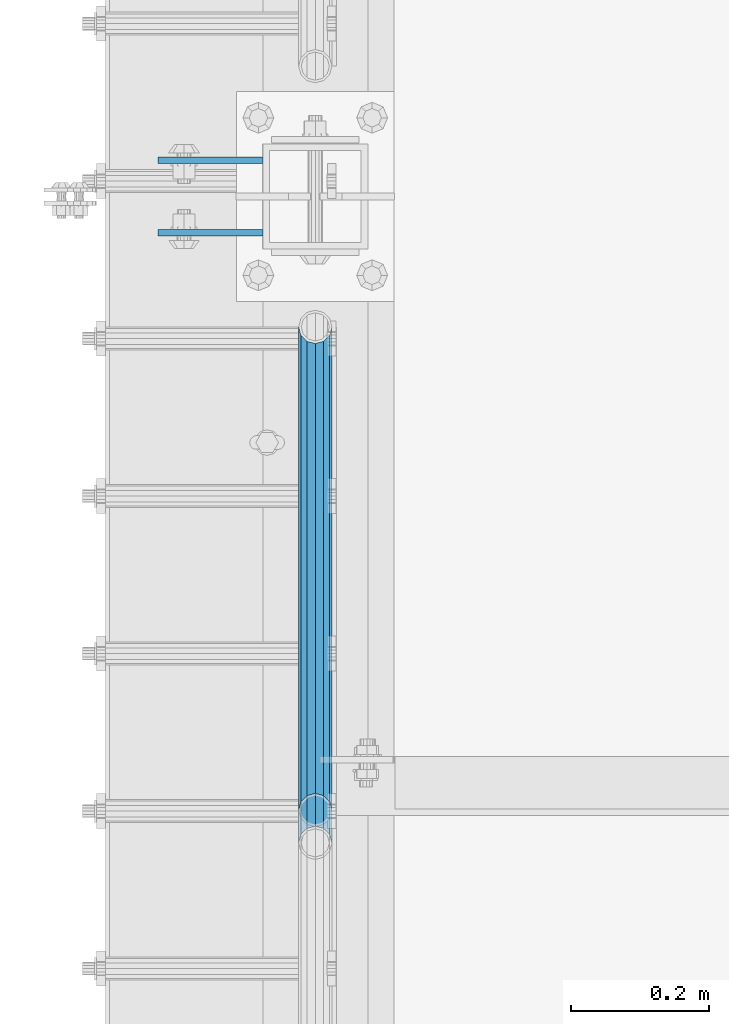
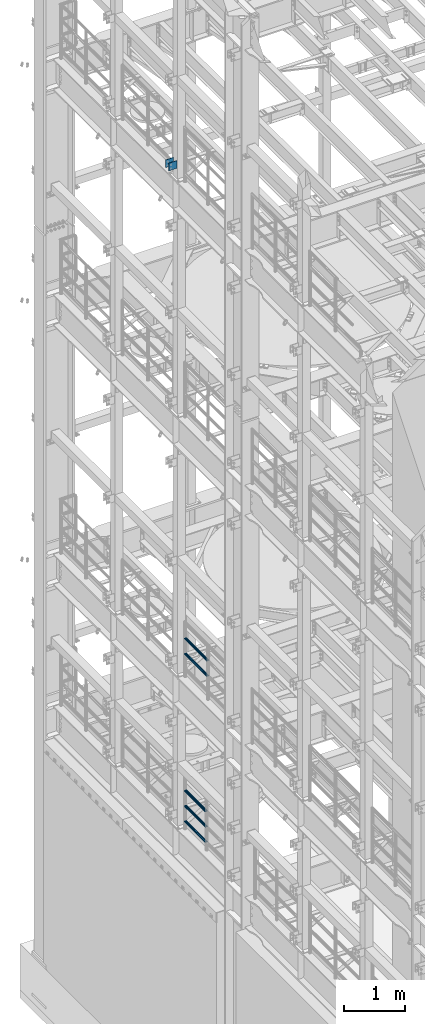
# One storey, part 1296 of 1876: 7 beams, 3 elements without a shape of their own.
"""IFC2X3 building model written with IfcOpenShell, lengths in millimetres."""

from ifc_helpers import new_model, si_unit, frame, origin_with_axes, place, context, subcontext, project, spatial, faceted_brep, material, type_object, element, aggregate, save


model = new_model("IFC2X3")

# Units and contexts
model_context = context("Model", 3, precision=1e-05, world=origin_with_axes())
body_context = subcontext(model_context, "Body", "Model", "MODEL_VIEW")
ifc_project = project(units=[si_unit("LENGTHUNIT", "METRE", prefix="MILLI"), si_unit("AREAUNIT", "SQUARE_METRE"), si_unit("VOLUMEUNIT", "CUBIC_METRE"), si_unit("MASSUNIT", "GRAM", prefix="KILO"), si_unit("TIMEUNIT", "SECOND"), si_unit("PLANEANGLEUNIT", "RADIAN"), si_unit("SOLIDANGLEUNIT", "STERADIAN"), si_unit("THERMODYNAMICTEMPERATUREUNIT", "DEGREE_CELSIUS"), si_unit("LUMINOUSINTENSITYUNIT", "LUMEN")], contexts=[model_context])

# Site, building, storey
site_placement = place(None, origin_with_axes())
site = spatial("IfcSite", under=ifc_project, at=site_placement, CompositionType="ELEMENT")
building_placement = place(site_placement, origin_with_axes())
building = spatial("IfcBuilding", under=site, at=building_placement, Name="Undefined", CompositionType="ELEMENT")
storey_placement = place(building_placement, origin_with_axes())
storey = spatial("IfcBuildingStorey", under=building, at=storey_placement, Name="Undefined", CompositionType="ELEMENT", Elevation=0.0)

# Assembly, beams
assembly_1_placement = place(storey_placement, origin_with_axes())
assembly_1 = element("IfcElementAssembly", 1, at=assembly_1_placement, inside=storey, Name="BEAM", AssemblyPlace="NOTDEFINED", PredefinedType="RIGID_FRAME")
ifc_material_1 = material(Name="STEEL/A36")
beam_type_1 = type_object("IfcBeamType", PredefinedType="NOTDEFINED")
beam_1_placement = place(assembly_1_placement, frame((-76.2000002548894, 9704.3875, 18275.3), z_axis=(0.0, 0.0, -1.0), x_axis=(-1.0, 0.0, 0.0)))
beam_1 = element("IfcBeam", 2, at=beam_1_placement, type_object=beam_type_1, material=ifc_material_1, Name="PLATE", context=body_context, shape_type="Brep", body=[
    faceted_brep([(0.0, 4.76249999999982, -76.1999999999998), (3.63797880709171e-12, 4.76249999999982, 76.1999969482422), (152.399993896484, 4.76250000000073, 76.1999969482422), (152.4, 4.76249999999982, -76.1999999999998), (3.63797880709171e-12, -4.76249999999982, 76.1999969482422), (152.399993896484, -4.76250000000073, 76.1999969482422), (0.0, -4.76249999999982, -76.1999999999998), (152.4, -4.76249999999982, -76.1999999999998)], [[[0, 1, 2, 3]], [[4, 5, 2, 1]], [[4, 6, 7, 5]], [[6, 0, 3, 7]], [[5, 7, 3, 2]], [[6, 4, 1, 0]]]),
])
beam_2_placement = place(assembly_1_placement, frame((-76.2000002548894, 9599.6125, 18275.3), z_axis=(0.0, 0.0, -1.0), x_axis=(-1.0, 0.0, 0.0)))
beam_2 = element("IfcBeam", 3, at=beam_2_placement, type_object=beam_type_1, material=ifc_material_1, Name="PLATE", context=body_context, shape_type="Brep", body=[
    faceted_brep([(0.0, 4.76249999999982, -76.1999999999998), (3.63797880709171e-12, 4.76249999999982, 76.1999969482422), (152.399993896484, 4.76250000000073, 76.1999969482422), (152.4, 4.76249999999982, -76.1999999999998), (3.63797880709171e-12, -4.76249999999982, 76.1999969482422), (152.399993896484, -4.76250000000073, 76.1999969482422), (0.0, -4.76249999999982, -76.1999999999998), (152.4, -4.76249999999982, -76.1999999999998)], [[[0, 1, 2, 3]], [[4, 5, 2, 1]], [[4, 6, 7, 5]], [[6, 0, 3, 7]], [[5, 7, 3, 2]], [[6, 4, 1, 0]]]),
])
aggregate(assembly_1, [beam_1, beam_2])

assembly_2_placement = place(storey_placement, origin_with_axes())
assembly_2 = element("IfcElementAssembly", 4, at=assembly_2_placement, inside=storey, Name="RAIL", AssemblyPlace="NOTDEFINED", PredefinedType="RIGID_FRAME")
ifc_material_2 = material()
beam_type_2 = type_object("IfcBeamType", Name="PIPE1-1/2SCH40", PredefinedType="NOTDEFINED")
beam_3_placement = place(assembly_2_placement, frame((-1.81898940354586e-12, 8713.7875, 8620.125), z_axis=(0.0, 0.0, -1.0), x_axis=(0.0, 1.0, 0.0)))
beam_3 = element("IfcBeam", 5, at=beam_3_placement, type_object=beam_type_2, material=ifc_material_2, Name="RAIL", ObjectType="PIPE1-1/2SCH40", context=body_context, shape_type="Brep", body=[
    faceted_brep([(0.0, 24.1299999999992, 0.0), (12.0650000000064, 20.8971929933177, -12.0649999999987), (12.0650000000064, 20.8971929933177, 12.0649999999987), (12.0650000000064, -20.8971929933177, 12.0649999999987), (12.0650000000064, -20.8971929933177, -12.0649999999987), (0.0, -24.1299999999992, 0.0), (20.8971929933249, -12.0650000000005, 20.8971929933177), (20.8971929933249, -12.0650000000005, 15.8661214311796), (15.2545715621445, -17.7076214311801, 10.2235000000001), (12.5151929933249, -20.4470000000001, 0.0), (15.2545715621445, -17.7076214311801, -10.2235000000001), (20.8971929933249, -12.0650000000005, -15.8661214311796), (20.8971929933249, -12.0650000000005, -20.8971929933177), (24.1300000000063, 0.0, -20.4470000000001), (24.1300000000063, 0.0, -24.130000000001), (21.3906214311868, -10.2235000000001, -17.7076214311819), (21.3906214311868, 10.2235000000001, -17.7076214311819), (20.8971929933249, 12.0650000000005, -15.8661214311796), (20.8971929933249, 12.0650000000005, -20.8971929933177), (15.2545715621445, 17.7076214311801, -10.2235000000001), (12.5151929933249, 20.4470000000001, 0.0), (15.2545715621445, 17.7076214311801, 10.2235000000001), (20.8971929933249, 12.0650000000005, 15.8661214311796), (20.8971929933249, 12.0650000000005, 20.8971929933177), (21.3906214311868, 10.2235000000001, 17.7076214311819), (24.1300000000064, 0.0, 20.4470000000001), (24.1300000000064, 0.0, 24.130000000001), (21.3906214311868, -10.2235000000001, 17.7076214311819), (748.982500000002, 24.1300000000001, 0.0), (736.917500000002, 20.8971929933186, -12.0649999999987), (728.085307006683, 12.0649999999996, -20.8971929933177), (748.982500000002, -24.1300000000001, 0.0), (736.917500000002, -20.8971929933186, -12.0649999999987), (736.917500000002, -20.8971929933186, 12.0649999999987), (728.085307006683, -12.0649999999996, 20.8971929933177), (728.085307006683, -12.0649999999996, -20.8971929933177), (724.852500000002, 0.0, -24.130000000001), (727.591878568821, 10.2235000000001, -17.7076214311819), (724.852500000002, 0.0, -20.4470000000001), (728.085307006683, 12.0649999999996, -15.8661214311796), (728.085307006683, -12.0649999999996, -15.8661214311796), (727.591878568821, -10.2235000000001, -17.7076214311819), (733.727928437864, -17.7076214311801, -10.2235000000001), (736.467307006683, -20.4470000000001, 0.0), (733.727928437864, -17.7076214311801, 10.2235000000001), (728.085307006683, -12.0649999999996, 15.8661214311796), (727.591878568821, -10.2235000000001, 17.7076214311819), (724.852500000002, 0.0, 20.4470000000001), (724.852500000002, 0.0, 24.130000000001), (728.085307006683, 12.0649999999996, 20.8971929933177), (736.917500000002, 20.8971929933186, 12.0649999999987), (728.085307006683, 12.0649999999996, 15.8661214311796), (733.727928437864, 17.7076214311801, 10.2235000000001), (736.467307006683, 20.4470000000001, 0.0), (733.727928437864, 17.7076214311801, -10.2235000000001), (727.591878568821, 10.2235000000001, 17.7076214311819)], [[[0, 1, 2]], [[3, 4, 5]], [[6, 7, 8, 9, 10, 11, 12, 4, 3]], [[13, 14, 12, 11, 15]], [[16, 17, 18, 14, 13]], [[2, 1, 18, 17, 19, 20, 21, 22, 23]], [[23, 22, 24, 25, 26]], [[26, 25, 27, 7, 6]], [[1, 0, 28, 29]], [[18, 1, 29, 30]], [[31, 32, 33]], [[6, 3, 33, 34]], [[3, 5, 31, 33]], [[5, 4, 32, 31]], [[4, 12, 35, 32]], [[12, 14, 36, 35]], [[14, 18, 30, 36]], [[37, 38, 36, 30, 39]], [[40, 35, 36, 38, 41]], [[33, 32, 35, 40, 42, 43, 44, 45, 34]], [[34, 45, 46, 47, 48]], [[26, 6, 34, 48]], [[2, 23, 49, 50]], [[23, 26, 48, 49]], [[0, 2, 50, 28]], [[28, 50, 29]], [[49, 51, 52, 53, 54, 39, 30, 29, 50]], [[48, 47, 55, 51, 49]], [[25, 24, 55, 47]], [[55, 24, 22, 21, 52, 51]], [[21, 20, 53, 52]], [[20, 19, 54, 53]], [[19, 17, 16, 37, 39, 54]], [[16, 13, 38, 37]], [[13, 15, 41, 38]], [[41, 15, 11, 10, 42, 40]], [[10, 9, 43, 42]], [[9, 8, 44, 43]], [[8, 7, 27, 46, 45, 44]], [[27, 25, 47, 46]]]),
])
beam_4_placement = place(assembly_2_placement, frame((-1.81898940354586e-12, 8713.7875, 8924.925), z_axis=(0.0, 0.0, -1.0), x_axis=(0.0, 1.0, 0.0)))
beam_4 = element("IfcBeam", 6, at=beam_4_placement, type_object=beam_type_2, material=ifc_material_2, Name="RAIL", ObjectType="PIPE1-1/2SCH40", context=body_context, shape_type="Brep", body=[
    faceted_brep([(0.0, 24.1299999999992, 0.0), (12.0650000000064, 20.8971929933177, -12.0649999999987), (12.0650000000064, 20.8971929933177, 12.0649999999987), (12.0650000000064, -20.8971929933177, 12.0649999999987), (12.0650000000064, -20.8971929933177, -12.0649999999987), (0.0, -24.1299999999992, 0.0), (20.8971929933249, -12.0650000000005, 20.8971929933177), (20.8971929933249, -12.0650000000005, 15.8661214311796), (15.2545715621445, -17.7076214311801, 10.2235000000001), (12.5151929933249, -20.4470000000001, 0.0), (15.2545715621445, -17.7076214311801, -10.2235000000001), (20.8971929933249, -12.0650000000005, -15.8661214311796), (20.8971929933249, -12.0650000000005, -20.8971929933177), (24.1300000000063, 0.0, -20.4470000000001), (24.1300000000063, 0.0, -24.130000000001), (21.3906214311868, -10.2235000000001, -17.7076214311819), (21.3906214311868, 10.2235000000001, -17.7076214311819), (20.8971929933249, 12.0650000000005, -15.8661214311796), (20.8971929933249, 12.0650000000005, -20.8971929933177), (15.2545715621445, 17.7076214311801, -10.2235000000001), (12.5151929933249, 20.4470000000001, 0.0), (15.2545715621445, 17.7076214311801, 10.2235000000001), (20.8971929933249, 12.0650000000005, 15.8661214311796), (20.8971929933249, 12.0650000000005, 20.8971929933177), (21.3906214311868, 10.2235000000001, 17.7076214311819), (24.1300000000064, 0.0, 20.4470000000001), (24.1300000000064, 0.0, 24.130000000001), (21.3906214311868, -10.2235000000001, 17.7076214311819), (748.982500000002, 24.1300000000001, 0.0), (736.917500000002, 20.8971929933186, -12.0649999999987), (728.085307006683, 12.0649999999996, -20.8971929933177), (748.982500000002, -24.1300000000001, 0.0), (736.917500000002, -20.8971929933186, -12.0649999999987), (736.917500000002, -20.8971929933186, 12.0649999999987), (728.085307006683, -12.0649999999996, 20.8971929933177), (728.085307006683, -12.0649999999996, -20.8971929933177), (724.852500000002, 0.0, -24.130000000001), (727.591878568821, 10.2235000000001, -17.7076214311819), (724.852500000002, 0.0, -20.4470000000001), (728.085307006683, 12.0649999999996, -15.8661214311796), (728.085307006683, -12.0649999999996, -15.8661214311796), (727.591878568821, -10.2235000000001, -17.7076214311819), (733.727928437864, -17.7076214311801, -10.2235000000001), (736.467307006683, -20.4470000000001, 0.0), (733.727928437864, -17.7076214311801, 10.2235000000001), (728.085307006683, -12.0649999999996, 15.8661214311796), (727.591878568821, -10.2235000000001, 17.7076214311819), (724.852500000002, 0.0, 20.4470000000001), (724.852500000002, 0.0, 24.130000000001), (728.085307006683, 12.0649999999996, 20.8971929933177), (736.917500000002, 20.8971929933186, 12.0649999999987), (728.085307006683, 12.0649999999996, 15.8661214311796), (733.727928437864, 17.7076214311801, 10.2235000000001), (736.467307006683, 20.4470000000001, 0.0), (733.727928437864, 17.7076214311801, -10.2235000000001), (727.591878568821, 10.2235000000001, 17.7076214311819)], [[[0, 1, 2]], [[3, 4, 5]], [[6, 7, 8, 9, 10, 11, 12, 4, 3]], [[13, 14, 12, 11, 15]], [[16, 17, 18, 14, 13]], [[2, 1, 18, 17, 19, 20, 21, 22, 23]], [[23, 22, 24, 25, 26]], [[26, 25, 27, 7, 6]], [[1, 0, 28, 29]], [[18, 1, 29, 30]], [[31, 32, 33]], [[6, 3, 33, 34]], [[3, 5, 31, 33]], [[5, 4, 32, 31]], [[4, 12, 35, 32]], [[12, 14, 36, 35]], [[14, 18, 30, 36]], [[37, 38, 36, 30, 39]], [[40, 35, 36, 38, 41]], [[33, 32, 35, 40, 42, 43, 44, 45, 34]], [[34, 45, 46, 47, 48]], [[26, 6, 34, 48]], [[2, 23, 49, 50]], [[23, 26, 48, 49]], [[0, 2, 50, 28]], [[28, 50, 29]], [[49, 51, 52, 53, 54, 39, 30, 29, 50]], [[48, 47, 55, 51, 49]], [[25, 24, 55, 47]], [[55, 24, 22, 21, 52, 51]], [[21, 20, 53, 52]], [[20, 19, 54, 53]], [[19, 17, 16, 37, 39, 54]], [[16, 13, 38, 37]], [[13, 15, 41, 38]], [[41, 15, 11, 10, 42, 40]], [[10, 9, 43, 42]], [[9, 8, 44, 43]], [[8, 7, 27, 46, 45, 44]], [[27, 25, 47, 46]]]),
])
aggregate(assembly_2, [beam_3, beam_4])

assembly_3_placement = place(storey_placement, origin_with_axes())
assembly_3 = element("IfcElementAssembly", 7, at=assembly_3_placement, inside=storey, Name="RAIL", AssemblyPlace="NOTDEFINED", PredefinedType="RIGID_FRAME")
beam_5_placement = place(assembly_3_placement, frame((-1.02100330182985e-11, 9462.77, 5292.725), z_axis=(0.0, 0.0, 1.0), x_axis=(0.0, -1.0, 0.0)))
beam_5 = element("IfcBeam", 8, at=beam_5_placement, type_object=beam_type_2, material=ifc_material_2, Name="RAIL", ObjectType="PIPE1-1/2SCH40", context=body_context, shape_type="Brep", body=[
    faceted_brep([(680.460307006681, -12.0649999999996, 20.8971929933186), (680.460307006681, -12.0649999999914, 15.8661214311887), (679.966878568822, -10.2235000000001, 17.7076214311801), (677.2275, 0.0, 20.4470000000001), (677.2275, 0.0, 24.1300000000001), (679.966878568817, 10.2235000000001, 17.7076214311801), (680.460307006681, 12.0650000000078, 15.8661214311724), (680.460307006681, 12.0649999999996, 20.8971929933186), (701.3575, 24.1300000000001, 0.0), (689.2925, 20.8971929933186, 12.0649999999996), (689.2925, 20.8971929933186, -12.0649999999996), (686.102928437854, 17.7076214311801, 10.2235000000001), (688.842307006673, 20.4470000000001, 0.0), (686.102928437854, 17.7076214311801, -10.2235000000001), (680.460307006681, 12.0650000000078, -15.8661214311724), (680.460307006681, 12.0649999999996, -20.8971929933186), (679.966878568817, 10.2235000000001, -17.7076214311801), (677.2275, 0.0, -20.4470000000001), (677.2275, 0.0, -24.1300000000001), (680.460307006681, -12.0649999999914, -15.8661214311887), (680.460307006681, -12.0649999999996, -20.8971929933186), (679.966878568822, -10.2235000000001, -17.7076214311801), (701.3575, -24.1299999999919, 0.0), (689.2925, -20.8971929933186, -12.0649999999996), (689.2925, -20.8971929933186, 12.0649999999996), (686.10292843787, -17.7076214311801, -10.2235000000001), (688.842307006689, -20.4470000000001, 0.0), (686.10292843787, -17.7076214311801, 10.2235000000001), (12.0650000000064, -20.8971929933177, -12.0649999999987), (20.8971929933249, -12.0650000000005, -20.8971929933177), (0.0, 24.1299999999992, 0.0), (12.0650000000064, 20.8971929933177, -12.0649999999987), (12.0650000000064, 20.8971929933177, 12.0649999999987), (20.8971929933249, 12.0650000000005, 20.8971929933177), (24.1300000000064, 0.0, 24.130000000001), (20.8971929933249, 12.0650000000005, -20.8971929933177), (24.1300000000063, 0.0, -24.130000000001), (24.1300000000063, 0.0, -20.4470000000001), (20.8971929933249, -12.0650000000005, -15.8661214311796), (21.3906214311868, -10.2235000000001, -17.7076214311819), (21.3906214311868, 10.2235000000001, -17.7076214311819), (20.8971929933249, 12.0650000000005, -15.8661214311796), (15.2545715621445, 17.7076214311801, -10.2235000000001), (12.5151929933249, 20.4470000000001, 0.0), (15.2545715621445, 17.7076214311801, 10.2235000000001), (20.8971929933249, 12.0650000000005, 15.8661214311796), (21.3906214311868, 10.2235000000001, 17.7076214311819), (24.1300000000064, 0.0, 20.4470000000001), (21.3906214311868, -10.2235000000001, 17.7076214311819), (20.8971929933249, -12.0650000000005, 15.8661214311796), (20.8971929933249, -12.0650000000005, 20.8971929933177), (12.0650000000064, -20.8971929933177, 12.0649999999987), (0.0, -24.1299999999992, 0.0), (15.2545715621445, -17.7076214311801, 10.2235000000001), (12.5151929933249, -20.4470000000001, 0.0), (15.2545715621445, -17.7076214311801, -10.2235000000001)], [[[0, 1, 2, 3, 4]], [[4, 3, 5, 6, 7]], [[8, 9, 10]], [[7, 6, 11, 12, 13, 14, 15, 10, 9]], [[16, 17, 18, 15, 14]], [[19, 20, 18, 17, 21]], [[22, 23, 24]], [[24, 23, 20, 19, 25, 26, 27, 1, 0]], [[28, 29, 20, 23]], [[30, 31, 32]], [[33, 34, 4, 7]], [[32, 33, 7, 9]], [[30, 32, 9, 8]], [[31, 30, 8, 10]], [[35, 31, 10, 15]], [[36, 35, 15, 18]], [[29, 36, 18, 20]], [[37, 36, 29, 38, 39]], [[40, 41, 35, 36, 37]], [[32, 31, 35, 41, 42, 43, 44, 45, 33]], [[33, 45, 46, 47, 34]], [[34, 47, 48, 49, 50]], [[34, 50, 0, 4]], [[50, 51, 24, 0]], [[51, 52, 22, 24]], [[52, 28, 23, 22]], [[51, 28, 52]], [[50, 49, 53, 54, 55, 38, 29, 28, 51]], [[55, 54, 26, 25]], [[21, 39, 38, 55, 25, 19]], [[37, 39, 21, 17]], [[40, 37, 17, 16]], [[42, 41, 40, 16, 14, 13]], [[43, 42, 13, 12]], [[44, 43, 12, 11]], [[5, 46, 45, 44, 11, 6]], [[47, 46, 5, 3]], [[48, 47, 3, 2]], [[53, 49, 48, 2, 1, 27]], [[54, 53, 27, 26]]]),
])
beam_6_placement = place(assembly_3_placement, frame((-1.81898940354586e-12, 8761.4125, 5597.525), z_axis=(0.0, 0.0, -1.0), x_axis=(0.0, 1.0, 0.0)))
beam_6 = element("IfcBeam", 9, at=beam_6_placement, type_object=beam_type_2, material=ifc_material_2, Name="RAIL", ObjectType="PIPE1-1/2SCH40", context=body_context, shape_type="Brep", body=[
    faceted_brep([(0.0, 24.1299999999992, 0.0), (12.0650000000064, 20.8971929933177, -12.0649999999987), (12.0650000000064, 20.8971929933177, 12.0649999999987), (12.0650000000064, -20.8971929933177, 12.0649999999987), (12.0650000000064, -20.8971929933177, -12.0649999999987), (0.0, -24.1299999999992, 0.0), (20.8971929933249, -12.0650000000005, 20.8971929933177), (20.8971929933249, -12.0650000000005, 15.8661214311796), (15.2545715621445, -17.7076214311801, 10.2235000000001), (12.5151929933249, -20.4470000000001, 0.0), (15.2545715621445, -17.7076214311801, -10.2235000000001), (20.8971929933249, -12.0650000000005, -15.8661214311796), (20.8971929933249, -12.0650000000005, -20.8971929933177), (24.1300000000063, 0.0, -20.4470000000001), (24.1300000000063, 0.0, -24.130000000001), (21.3906214311868, -10.2235000000001, -17.7076214311819), (21.3906214311868, 10.2235000000001, -17.7076214311819), (20.8971929933249, 12.0650000000005, -15.8661214311796), (20.8971929933249, 12.0650000000005, -20.8971929933177), (15.2545715621445, 17.7076214311801, -10.2235000000001), (12.5151929933249, 20.4470000000001, 0.0), (15.2545715621445, 17.7076214311801, 10.2235000000001), (20.8971929933249, 12.0650000000005, 15.8661214311796), (20.8971929933249, 12.0650000000005, 20.8971929933177), (21.3906214311868, 10.2235000000001, 17.7076214311819), (24.1300000000064, 0.0, 20.4470000000001), (24.1300000000064, 0.0, 24.130000000001), (21.3906214311868, -10.2235000000001, 17.7076214311819), (701.3575, 24.1300000000001, 0.0), (689.2925, 20.8971929933186, -12.0649999999996), (680.460307006681, 12.0649999999996, -20.8971929933186), (701.3575, -24.1299999999919, 0.0), (689.2925, -20.8971929933186, -12.0649999999996), (689.2925, -20.8971929933186, 12.0649999999996), (680.460307006681, -12.0649999999996, 20.8971929933186), (680.460307006681, -12.0649999999996, -20.8971929933186), (677.2275, 0.0, -24.1300000000001), (679.966878568817, 10.2235000000001, -17.7076214311801), (677.2275, 0.0, -20.4470000000001), (680.460307006681, 12.0650000000078, -15.8661214311724), (680.460307006681, -12.0649999999914, -15.8661214311887), (679.966878568822, -10.2235000000001, -17.7076214311801), (686.10292843787, -17.7076214311801, -10.2235000000001), (688.842307006689, -20.4470000000001, 0.0), (686.10292843787, -17.7076214311801, 10.2235000000001), (680.460307006681, -12.0649999999914, 15.8661214311887), (679.966878568822, -10.2235000000001, 17.7076214311801), (677.2275, 0.0, 20.4470000000001), (677.2275, 0.0, 24.1300000000001), (680.460307006681, 12.0649999999996, 20.8971929933186), (689.2925, 20.8971929933186, 12.0649999999996), (680.460307006681, 12.0650000000078, 15.8661214311724), (686.102928437854, 17.7076214311801, 10.2235000000001), (688.842307006673, 20.4470000000001, 0.0), (686.102928437854, 17.7076214311801, -10.2235000000001), (679.966878568817, 10.2235000000001, 17.7076214311801)], [[[0, 1, 2]], [[3, 4, 5]], [[6, 7, 8, 9, 10, 11, 12, 4, 3]], [[13, 14, 12, 11, 15]], [[16, 17, 18, 14, 13]], [[2, 1, 18, 17, 19, 20, 21, 22, 23]], [[23, 22, 24, 25, 26]], [[26, 25, 27, 7, 6]], [[1, 0, 28, 29]], [[18, 1, 29, 30]], [[31, 32, 33]], [[6, 3, 33, 34]], [[3, 5, 31, 33]], [[5, 4, 32, 31]], [[4, 12, 35, 32]], [[12, 14, 36, 35]], [[14, 18, 30, 36]], [[37, 38, 36, 30, 39]], [[40, 35, 36, 38, 41]], [[33, 32, 35, 40, 42, 43, 44, 45, 34]], [[34, 45, 46, 47, 48]], [[26, 6, 34, 48]], [[2, 23, 49, 50]], [[23, 26, 48, 49]], [[0, 2, 50, 28]], [[28, 50, 29]], [[49, 51, 52, 53, 54, 39, 30, 29, 50]], [[48, 47, 55, 51, 49]], [[25, 24, 55, 47]], [[55, 24, 22, 21, 52, 51]], [[21, 20, 53, 52]], [[20, 19, 54, 53]], [[19, 17, 16, 37, 39, 54]], [[16, 13, 38, 37]], [[13, 15, 41, 38]], [[41, 15, 11, 10, 42, 40]], [[10, 9, 43, 42]], [[9, 8, 44, 43]], [[8, 7, 27, 46, 45, 44]], [[27, 25, 47, 46]]]),
])
beam_7_placement = place(assembly_3_placement, frame((-1.81898940354586e-12, 8761.4125, 5902.325), z_axis=(0.0, 0.0, -1.0), x_axis=(0.0, 1.0, 0.0)))
beam_7 = element("IfcBeam", 10, at=beam_7_placement, type_object=beam_type_2, material=ifc_material_2, Name="RAIL", ObjectType="PIPE1-1/2SCH40", context=body_context, shape_type="Brep", body=[
    faceted_brep([(0.0, 24.1299999999992, 0.0), (12.0650000000064, 20.8971929933177, -12.0649999999987), (12.0650000000064, 20.8971929933177, 12.0649999999987), (12.0650000000064, -20.8971929933177, 12.0649999999987), (12.0650000000064, -20.8971929933177, -12.0649999999987), (0.0, -24.1299999999992, 0.0), (20.8971929933249, -12.0650000000005, 20.8971929933177), (20.8971929933249, -12.0650000000005, 15.8661214311796), (15.2545715621445, -17.7076214311801, 10.2235000000001), (12.5151929933249, -20.4470000000001, 0.0), (15.2545715621445, -17.7076214311801, -10.2235000000001), (20.8971929933249, -12.0650000000005, -15.8661214311796), (20.8971929933249, -12.0650000000005, -20.8971929933177), (24.1300000000063, 0.0, -20.4470000000001), (24.1300000000063, 0.0, -24.130000000001), (21.3906214311868, -10.2235000000001, -17.7076214311819), (21.3906214311868, 10.2235000000001, -17.7076214311819), (20.8971929933249, 12.0650000000005, -15.8661214311796), (20.8971929933249, 12.0650000000005, -20.8971929933177), (15.2545715621445, 17.7076214311801, -10.2235000000001), (12.5151929933249, 20.4470000000001, 0.0), (15.2545715621445, 17.7076214311801, 10.2235000000001), (20.8971929933249, 12.0650000000005, 15.8661214311796), (20.8971929933249, 12.0650000000005, 20.8971929933177), (21.3906214311868, 10.2235000000001, 17.7076214311819), (24.1300000000064, 0.0, 20.4470000000001), (24.1300000000064, 0.0, 24.130000000001), (21.3906214311868, -10.2235000000001, 17.7076214311819), (701.3575, 24.1300000000001, 0.0), (689.2925, 20.8971929933186, -12.0649999999996), (680.460307006681, 12.0649999999996, -20.8971929933186), (701.3575, -24.1299999999919, 0.0), (689.2925, -20.8971929933186, -12.0649999999996), (689.2925, -20.8971929933186, 12.0649999999996), (680.460307006681, -12.0649999999996, 20.8971929933186), (680.460307006681, -12.0649999999996, -20.8971929933186), (677.2275, 0.0, -24.1300000000001), (679.966878568817, 10.2235000000001, -17.7076214311801), (677.2275, 0.0, -20.4470000000001), (680.460307006681, 12.0650000000078, -15.8661214311724), (680.460307006681, -12.0649999999914, -15.8661214311887), (679.966878568822, -10.2235000000001, -17.7076214311801), (686.10292843787, -17.7076214311801, -10.2235000000001), (688.842307006689, -20.4470000000001, 0.0), (686.10292843787, -17.7076214311801, 10.2235000000001), (680.460307006681, -12.0649999999914, 15.8661214311887), (679.966878568822, -10.2235000000001, 17.7076214311801), (677.2275, 0.0, 20.4470000000001), (677.2275, 0.0, 24.1300000000001), (680.460307006681, 12.0649999999996, 20.8971929933186), (689.2925, 20.8971929933186, 12.0649999999996), (680.460307006681, 12.0650000000078, 15.8661214311724), (686.102928437854, 17.7076214311801, 10.2235000000001), (688.842307006673, 20.4470000000001, 0.0), (686.102928437854, 17.7076214311801, -10.2235000000001), (679.966878568817, 10.2235000000001, 17.7076214311801)], [[[0, 1, 2]], [[3, 4, 5]], [[6, 7, 8, 9, 10, 11, 12, 4, 3]], [[13, 14, 12, 11, 15]], [[16, 17, 18, 14, 13]], [[2, 1, 18, 17, 19, 20, 21, 22, 23]], [[23, 22, 24, 25, 26]], [[26, 25, 27, 7, 6]], [[1, 0, 28, 29]], [[18, 1, 29, 30]], [[31, 32, 33]], [[6, 3, 33, 34]], [[3, 5, 31, 33]], [[5, 4, 32, 31]], [[4, 12, 35, 32]], [[12, 14, 36, 35]], [[14, 18, 30, 36]], [[37, 38, 36, 30, 39]], [[40, 35, 36, 38, 41]], [[33, 32, 35, 40, 42, 43, 44, 45, 34]], [[34, 45, 46, 47, 48]], [[26, 6, 34, 48]], [[2, 23, 49, 50]], [[23, 26, 48, 49]], [[0, 2, 50, 28]], [[28, 50, 29]], [[49, 51, 52, 53, 54, 39, 30, 29, 50]], [[48, 47, 55, 51, 49]], [[25, 24, 55, 47]], [[55, 24, 22, 21, 52, 51]], [[21, 20, 53, 52]], [[20, 19, 54, 53]], [[19, 17, 16, 37, 39, 54]], [[16, 13, 38, 37]], [[13, 15, 41, 38]], [[41, 15, 11, 10, 42, 40]], [[10, 9, 43, 42]], [[9, 8, 44, 43]], [[8, 7, 27, 46, 45, 44]], [[27, 25, 47, 46]]]),
])
aggregate(assembly_3, [beam_5, beam_6, beam_7])

save(model, "model.ifc")
